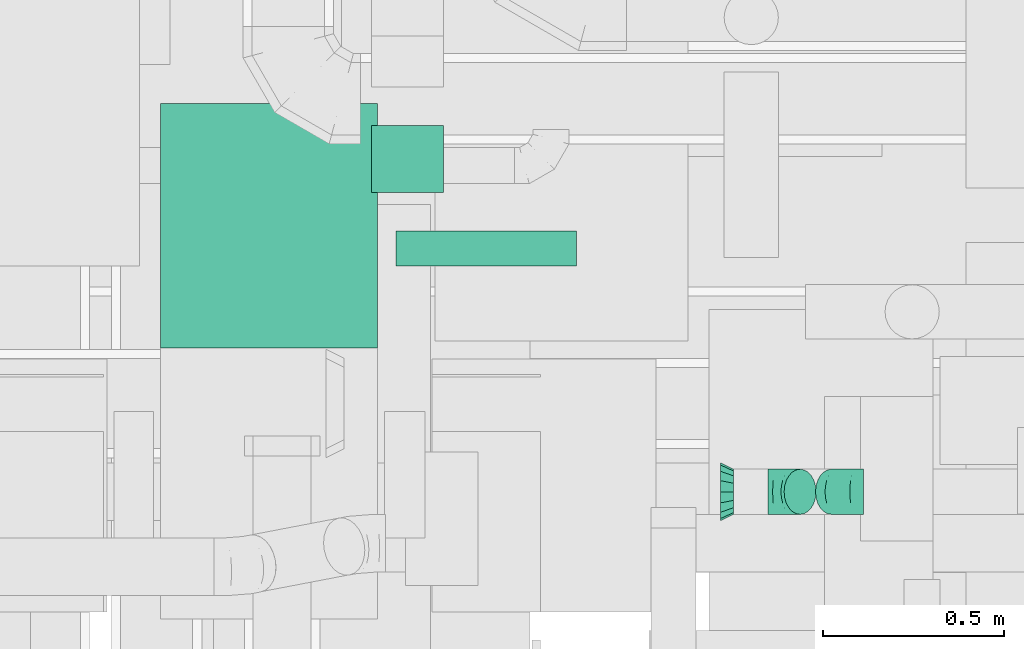
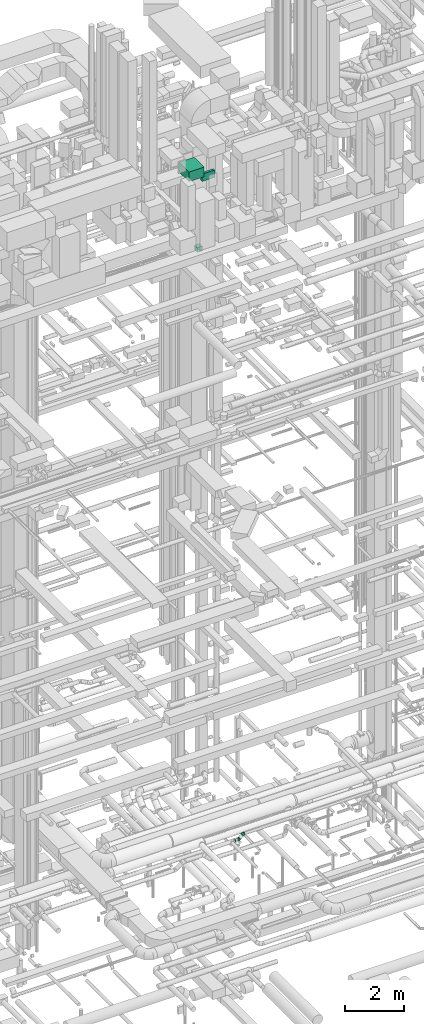
# One storey, part 184 of 337: 3 flow fittings, 3 flow segments.
"""IFC2X3 building model written with IfcOpenShell, lengths in millimetres."""

from ifc_helpers import new_model, entity, si_unit, converted_unit, derived_unit, direction, frame, origin, origin_2d_with_axis, place, context, subcontext, project, spatial, rectangle, extrude, faceted_brep, source, transform, mapped, material, type_object, type_shapes, element, save


model = new_model("IFC2X3")

# Units and contexts
model_context = context("Model", 3, precision=0.01, world=origin(), true_north=direction((6.12303176911189e-17, 1.0)))
body_context = subcontext(model_context, "Body", "Model", "MODEL_VIEW")
ifc_project = project(units=[si_unit("LENGTHUNIT", "METRE", prefix="MILLI"), si_unit("AREAUNIT", "SQUARE_METRE"), si_unit("VOLUMEUNIT", "CUBIC_METRE"), converted_unit("PLANEANGLEUNIT", "DEGREE", entity("IfcRatioMeasure", 0.0174532925199433), si_unit("PLANEANGLEUNIT", "RADIAN"), dimensions=[0, 0, 0, 0, 0, 0, 0]), si_unit("MASSUNIT", "GRAM", prefix="KILO"), derived_unit("MASSDENSITYUNIT", [(si_unit("MASSUNIT", "GRAM", prefix="KILO"), 1), (si_unit("LENGTHUNIT", "METRE"), -3)]), derived_unit("MOMENTOFINERTIAUNIT", [(si_unit("LENGTHUNIT", "METRE"), 4)]), si_unit("TIMEUNIT", "SECOND"), si_unit("FREQUENCYUNIT", "HERTZ"), si_unit("THERMODYNAMICTEMPERATUREUNIT", "DEGREE_CELSIUS"), derived_unit("THERMALTRANSMITTANCEUNIT", [(si_unit("MASSUNIT", "GRAM", prefix="KILO"), 1), (si_unit("THERMODYNAMICTEMPERATUREUNIT", "KELVIN"), -1), (si_unit("TIMEUNIT", "SECOND"), -3)]), derived_unit("VOLUMETRICFLOWRATEUNIT", [(si_unit("LENGTHUNIT", "METRE"), 3), (si_unit("TIMEUNIT", "SECOND"), -1)]), derived_unit("MASSFLOWRATEUNIT", [(si_unit("MASSUNIT", "GRAM", prefix="KILO"), 1), (si_unit("TIMEUNIT", "SECOND"), -1)]), derived_unit("ROTATIONALFREQUENCYUNIT", [(si_unit("TIMEUNIT", "SECOND"), -1)]), si_unit("ELECTRICCURRENTUNIT", "AMPERE"), si_unit("ELECTRICVOLTAGEUNIT", "VOLT"), si_unit("POWERUNIT", "WATT"), si_unit("FORCEUNIT", "NEWTON", prefix="KILO"), si_unit("ILLUMINANCEUNIT", "LUX"), si_unit("LUMINOUSFLUXUNIT", "LUMEN"), si_unit("LUMINOUSINTENSITYUNIT", "CANDELA"), derived_unit("USERDEFINED", [(si_unit("MASSUNIT", "GRAM", prefix="KILO"), -1), (si_unit("LENGTHUNIT", "METRE"), -2), (si_unit("TIMEUNIT", "SECOND"), 3), (si_unit("LUMINOUSFLUXUNIT", "LUMEN"), 1)]), derived_unit("LINEARVELOCITYUNIT", [(si_unit("LENGTHUNIT", "METRE"), 1), (si_unit("TIMEUNIT", "SECOND"), -1)]), si_unit("PRESSUREUNIT", "PASCAL"), derived_unit("USERDEFINED", [(si_unit("LENGTHUNIT", "METRE"), -2), (si_unit("MASSUNIT", "GRAM", prefix="KILO"), 1), (si_unit("TIMEUNIT", "SECOND"), -2)]), derived_unit("LINEARFORCEUNIT", [(si_unit("MASSUNIT", "GRAM", prefix="KILO"), 1), (si_unit("LENGTHUNIT", "METRE"), 1), (si_unit("TIMEUNIT", "SECOND"), -2), (si_unit("LENGTHUNIT", "METRE"), -1)]), derived_unit("PLANARFORCEUNIT", [(si_unit("MASSUNIT", "GRAM", prefix="KILO"), 1), (si_unit("LENGTHUNIT", "METRE"), 1), (si_unit("TIMEUNIT", "SECOND"), -2), (si_unit("LENGTHUNIT", "METRE"), -2)])], contexts=[model_context])

# Site, building, storey
site_placement = place(None, origin())
site = spatial("IfcSite", under=ifc_project, at=site_placement, CompositionType="ELEMENT")
building_placement = place(site_placement, origin())
building = spatial("IfcBuilding", under=site, at=building_placement, CompositionType="ELEMENT")
storey_placement = place(building_placement, origin())
storey = spatial("IfcBuildingStorey", under=building, at=storey_placement, CompositionType="ELEMENT", Elevation=0.0)

# Flow segments
duct_segment_type = type_object("IfcDuctSegmentType", PredefinedType="NOTDEFINED")
flow_segment_1_placement = place(storey_placement, frame((50724.61, 8966.84, 30500.0)))
element("IfcFlowSegment", 1, at=flow_segment_1_placement, inside=storey, type_object=duct_segment_type, context=body_context, shape_type="SweptSolid", body=[
    extrude(rectangle(XDim=97.0000000001111, YDim=499.999999999999, at=origin_2d_with_axis()), frame((250.0, 48.5, 0.0), z_axis=(0.0, 0.0, 1.0), x_axis=(0.0, -1.0, 0.0)), (0.0, 0.0, 1.0), 300.000000000001),
])
flow_segment_2_placement = place(storey_placement, frame((50073.61, 8740.0, 30854.99)))
element("IfcFlowSegment", 2, at=flow_segment_2_placement, inside=storey, type_object=duct_segment_type, context=body_context, shape_type="SweptSolid", body=[
    extrude(rectangle(XDim=677.000000347411, YDim=600.000000000002, at=origin_2d_with_axis()), frame((300.0, 338.5, 0.01), z_axis=(0.0, 1.7753785560717e-05, 1.0), x_axis=(8.19732655769868e-09, 1.0, -1.7753785560717e-05)), (0.0, 0.0, 1.0), 399.999999999999),
])
flow_segment_3_placement = place(storey_placement, frame((50656.62, 9169.98, 27450.0)))
element("IfcFlowSegment", 3, at=flow_segment_3_placement, inside=storey, type_object=duct_segment_type, context=body_context, shape_type="SweptSolid", body=[
    extrude(rectangle(XDim=186.566609406722, YDim=199.999999999998, at=origin_2d_with_axis()), frame((100.0, 93.28, 0.0), z_axis=(0.0, 0.0, 1.0), x_axis=(0.0, 1.0, 0.0)), (0.0, 0.0, 1.0), 199.999999999998),
])

# Flow fittings
ifc_material = material()
duct_fitting_type_1 = type_object("IfcDuctFittingType", PredefinedType="NOTDEFINED", material=ifc_material)
shared_shape_1 = source(origin(), body_context, "Body", "Brep", [
    faceted_brep([(35.0, 0.0, -80.0), (35.0, 12.81, -77.45), (35.0, 30.61, -73.91), (35.0, 43.59, -65.24), (35.0, 56.57, -56.57), (35.0, 65.24, -43.59), (35.0, 73.91, -30.61), (35.0, 76.96, -15.31), (35.0, 80.0, 0.0), (35.0, 77.45, 12.81), (35.0, 73.91, 30.61), (35.0, 65.24, 43.59), (35.0, 56.57, 56.57), (35.0, 43.59, 65.24), (35.0, 30.61, 73.91), (35.0, 15.31, 76.96), (35.0, 0.0, 80.0), (35.0, -12.81, 77.45), (35.0, -30.61, 73.91), (35.0, -43.59, 65.24), (35.0, -56.57, 56.57), (35.0, -65.24, 43.59), (35.0, -73.91, 30.61), (35.0, -76.96, 15.31), (35.0, -80.0, 0.0), (35.0, -77.45, -12.81), (35.0, -73.91, -30.61), (35.0, -65.24, -43.59), (35.0, -56.57, -56.57), (35.0, -43.59, -65.24), (35.0, -30.61, -73.91), (35.0, -15.31, -76.96), (0.0, -23.92, -57.74), (0.0, -34.06, -50.97), (0.0, -44.19, -44.19), (0.0, -50.97, -34.06), (0.0, -57.74, -23.92), (0.0, -60.12, -11.96), (0.0, -62.5, 0.0), (0.0, -60.12, 11.96), (0.0, -57.74, 23.92), (0.0, -50.97, 34.06), (0.0, -44.19, 44.19), (0.0, -34.06, 50.97), (0.0, -23.92, 57.74), (0.0, -11.96, 60.12), (0.0, 0.0, 62.5), (0.0, 11.96, 60.12), (0.0, 23.92, 57.74), (0.0, 34.06, 50.97), (0.0, 44.19, 44.19), (0.0, 50.97, 34.06), (0.0, 57.74, 23.92), (0.0, 60.12, 11.96), (0.0, 62.5, 0.0), (0.0, 60.12, -11.96), (0.0, 57.74, -23.92), (0.0, 50.97, -34.06), (0.0, 44.19, -44.19), (0.0, 34.06, -50.97), (0.0, 23.92, -57.74), (0.0, 11.96, -60.12), (0.0, 0.0, -62.5), (0.0, -11.96, -60.12)], [[[0, 1, 2, 3, 4, 5, 6, 7, 8, 9, 10, 11, 12, 13, 14, 15, 16, 17, 18, 19, 20, 21, 22, 23, 24, 25, 26, 27, 28, 29, 30, 31]], [[32, 33, 34, 35, 36, 37, 38, 39, 40, 41, 42, 43, 44, 45, 46, 47, 48, 49, 50, 51, 52, 53, 54, 55, 56, 57, 58, 59, 60, 61, 62, 63]], [[10, 9, 8, 54, 53, 52]], [[11, 10, 52, 51, 50, 12]], [[48, 14, 13, 12, 50, 49]], [[46, 16, 15, 14, 48, 47]], [[18, 17, 16, 46, 45, 44]], [[19, 18, 44, 43, 42, 20]], [[40, 22, 21, 20, 42, 41]], [[38, 24, 23, 22, 40, 39]], [[26, 25, 24, 38, 37, 36]], [[27, 26, 36, 35, 34, 28]], [[32, 30, 29, 28, 34, 33]], [[62, 0, 31, 30, 32, 63]], [[2, 1, 0, 62, 61, 60]], [[3, 2, 60, 59, 58, 4]], [[56, 6, 5, 4, 58, 57]], [[54, 8, 7, 6, 56, 55]]]),
])
type_shapes(duct_fitting_type_1, [shared_shape_1])
flow_fitting_placement = place(storey_placement, frame((51658.34, 8342.51, 3240.0), z_axis=(0.0, 0.0, 1.0), x_axis=(-1.0, 0.0, 0.0)))
element("IfcFlowFitting", 4, at=flow_fitting_placement, inside=storey, type_object=duct_fitting_type_1, material=ifc_material, context=body_context, shape_type="MappedRepresentation", body=[
    mapped(shared_shape_1, transform((0.0, 0.0, 0.0), scale=1.0)),
])
duct_fitting_type_2 = type_object("IfcDuctFittingType", PredefinedType="NOTDEFINED", material=ifc_material)
shared_shape_2 = source(origin(), body_context, "Body", "Brep", [
    faceted_brep([(-51.78, 0.0, -62.5), (-51.78, -16.18, -60.37), (-51.78, -31.25, -54.13), (-51.78, -44.19, -44.19), (-51.78, -54.13, -31.25), (-51.78, -60.37, -16.18), (-51.78, -62.5, 0.0), (-51.78, -60.37, 16.18), (-51.78, -54.13, 31.25), (-51.78, -44.19, 44.19), (-51.78, -31.25, 54.13), (-51.78, -16.18, 60.37), (-51.78, 0.0, 62.5), (-51.78, 16.18, 60.37), (-51.78, 31.25, 54.13), (-51.78, 44.19, 44.19), (-51.78, 54.13, 31.25), (-51.78, 60.37, 16.18), (-51.78, 62.5, 0.0), (-51.78, 60.37, -16.18), (-51.78, 54.13, -31.25), (-51.78, 44.19, -44.19), (-51.78, 31.25, -54.13), (-51.78, 16.18, -60.37), (-30.13, 16.18, 60.37), (-33.13, 31.25, 54.13), (-26.91, 0.0, 62.5), (-35.7, 44.19, 44.19), (-38.92, 60.37, 16.18), (-39.34, 62.5, 0.0), (-37.68, 54.13, 31.25), (-37.68, 54.13, -31.25), (-35.7, 44.19, -44.19), (-38.92, 60.37, -16.18), (-30.13, 16.18, -60.37), (-26.91, 0.0, -62.5), (-33.13, 31.25, -54.13), (-23.7, -16.18, -60.37), (-20.7, -31.25, -54.13), (-18.12, -44.19, -44.19), (-16.15, -54.13, -31.25), (-14.9, -60.37, -16.18), (-14.48, -62.5, 0.0), (-14.9, -60.37, 16.18), (-16.15, -54.13, 31.25), (-18.12, -44.19, 44.19), (-20.7, -31.25, 54.13), (-23.7, -16.18, 60.37), (9.87, 32.74, 60.37), (1.33, 45.52, 54.13), (19.03, 19.03, 62.5), (-6.0, 56.5, 44.19), (-11.63, 64.92, 31.25), (-15.17, 70.21, 16.18), (-16.37, 72.02, 0.0), (-15.17, 70.21, -16.18), (-11.63, 64.92, -31.25), (-6.0, 56.5, -44.19), (9.87, 32.74, -60.37), (19.03, 19.03, -62.5), (1.33, 45.52, -54.13), (28.19, 5.32, -60.37), (36.73, -7.46, -54.13), (44.06, -18.44, -44.19), (49.69, -26.86, -31.25), (53.23, -32.15, -16.18), (54.43, -33.95, 0.0), (53.23, -32.15, 16.18), (49.69, -26.86, 31.25), (44.06, -18.44, 44.19), (36.73, -7.46, 54.13), (28.19, 5.32, 60.37), (36.61, 36.61, 62.5), (25.17, 48.05, 60.37), (14.51, 58.71, 54.13), (5.36, 67.86, 44.19), (-1.66, 74.88, 31.25), (-6.08, 79.3, 16.18), (-7.58, 80.81, 0.0), (-6.08, 79.3, -16.18), (-1.66, 74.88, -31.25), (5.36, 67.86, -44.19), (25.17, 48.05, -60.37), (36.61, 36.61, -62.5), (14.51, 58.71, -54.13), (48.05, 25.17, -60.37), (58.71, 14.51, -54.13), (67.86, 5.36, -44.19), (79.3, -6.08, -16.18), (80.81, -7.58, 0.0), (74.88, -1.66, -31.25), (79.3, -6.08, 16.18), (74.88, -1.66, 31.25), (67.86, 5.36, 44.19), (58.71, 14.51, 54.13), (48.05, 25.17, 60.37)], [[[0, 1, 2, 3, 4, 5, 6, 7, 8, 9, 10, 11, 12, 13, 14, 15, 16, 17, 18, 19, 20, 21, 22, 23]], [[24, 25, 14, 13]], [[26, 24, 13, 12]], [[14, 25, 27, 15]], [[28, 29, 18, 17]], [[30, 28, 17, 16]], [[15, 27, 30, 16]], [[20, 31, 32, 21]], [[33, 31, 20, 19]], [[18, 29, 33, 19]], [[34, 35, 0, 23]], [[36, 34, 23, 22]], [[32, 36, 22, 21]], [[2, 1, 37, 38]], [[3, 2, 38, 39]], [[0, 35, 37, 1]], [[5, 4, 40, 41]], [[6, 5, 41, 42]], [[39, 40, 4, 3]], [[6, 42, 43, 7]], [[7, 43, 44, 8]], [[8, 44, 45, 9]], [[10, 46, 47, 11]], [[11, 47, 26, 12]], [[9, 45, 46, 10]], [[48, 49, 25, 24]], [[50, 48, 24, 26]], [[51, 27, 25, 49]], [[52, 53, 28, 30]], [[51, 52, 30, 27]], [[29, 28, 53, 54]], [[55, 56, 31, 33]], [[54, 55, 33, 29]], [[32, 31, 56, 57]], [[58, 59, 35, 34]], [[60, 58, 34, 36]], [[57, 60, 36, 32]], [[37, 35, 59, 61]], [[38, 37, 61, 62]], [[39, 38, 62, 63]], [[41, 40, 64, 65]], [[42, 41, 65, 66]], [[63, 64, 40, 39]], [[43, 42, 66, 67]], [[44, 43, 67, 68]], [[68, 69, 45, 44]], [[46, 45, 69, 70]], [[47, 46, 70, 71]], [[26, 47, 71, 50]], [[48, 50, 72, 73]], [[49, 48, 73, 74]], [[51, 49, 74, 75]], [[53, 52, 76, 77]], [[54, 53, 77, 78]], [[51, 75, 76, 52]], [[54, 78, 79, 55]], [[55, 79, 80, 56]], [[56, 80, 81, 57]], [[82, 83, 59, 58]], [[84, 82, 58, 60]], [[60, 57, 81, 84]], [[59, 83, 85, 61]], [[61, 85, 86, 62]], [[62, 86, 87, 63]], [[88, 89, 66, 65]], [[90, 88, 65, 64]], [[63, 87, 90, 64]], [[67, 66, 89, 91]], [[68, 67, 91, 92]], [[69, 68, 92, 93]], [[71, 70, 94, 95]], [[50, 71, 95, 72]], [[93, 94, 70, 69]], [[82, 84, 81, 80, 79, 78, 77, 76, 75, 74, 73, 72, 95, 94, 93, 92, 91, 89, 88, 90, 87, 86, 85, 83]]]),
])
type_shapes(duct_fitting_type_2, [shared_shape_2])
for number, where, z_axis, x_axis in (
    (5, (51806.56, 8342.51, 3240.0), (0.0, -1.0, 0.0), (1.0, 0.0, 0.0)),
    (6, (51966.56, 8342.51, 3400.0), (0.0, 1.0, 0.0), (0.70710652309233, 0.0, 0.707107039280671)),
):
    element("IfcFlowFitting", number, at=place(storey_placement, frame(where, z_axis=z_axis, x_axis=x_axis)), inside=storey, type_object=duct_fitting_type_2, material=ifc_material, context=body_context, shape_type="MappedRepresentation", body=[
        mapped(shared_shape_2, transform((0.0, 0.0, 0.0), scale=1.0)),
    ])

save(model, "model.ifc")
